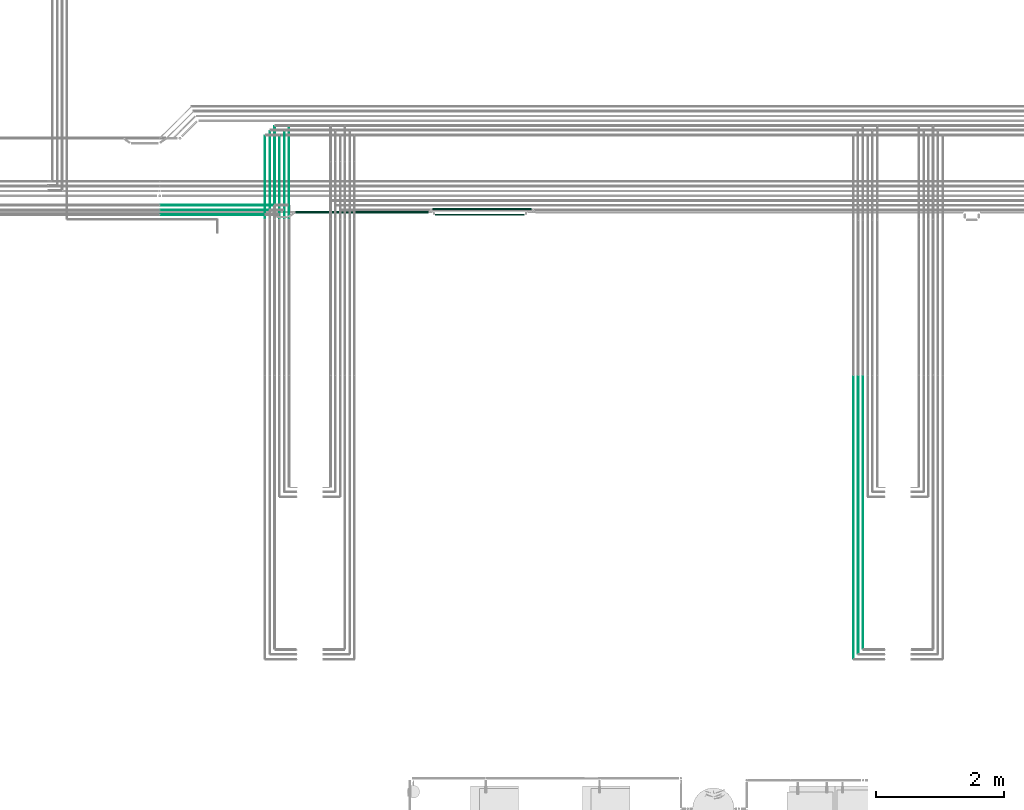
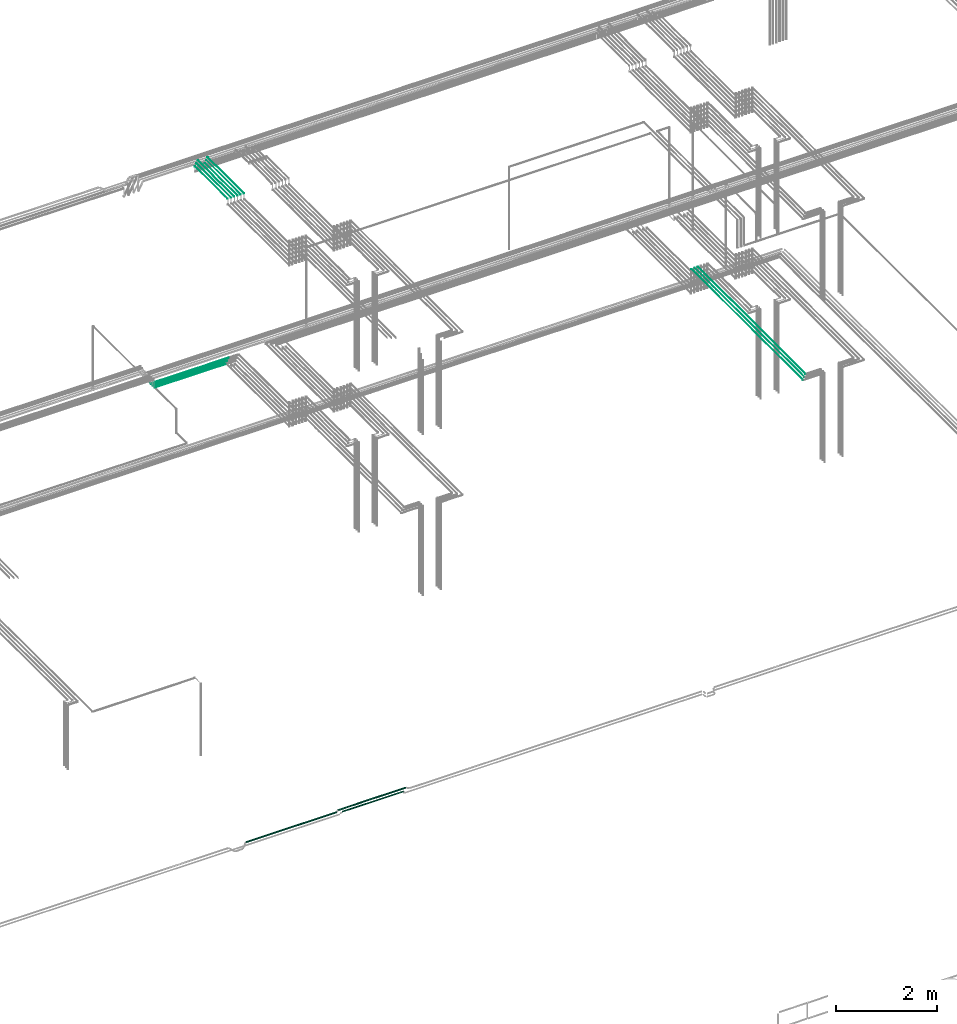
# One storey, part 55 of 331: 15 flow segments.
"""IFC2X3 building model written with IfcOpenShell, lengths in millimetres."""

from ifc_helpers import new_model, entity, si_unit, converted_unit, derived_unit, direction, frame, frame_2d, origin, origin_2d_with_axis, place, context, subcontext, project, spatial, circle, extrude, type_object, element, save


model = new_model("IFC2X3")

# Units and contexts
model_context = context("Model", 3, precision=0.01, world=origin(), true_north=direction((6.12303176911189e-17, 1.0)))
body_context = subcontext(model_context, "Body", "Model", "MODEL_VIEW")
ifc_project = project(units=[si_unit("LENGTHUNIT", "METRE", prefix="MILLI"), si_unit("AREAUNIT", "SQUARE_METRE"), si_unit("VOLUMEUNIT", "CUBIC_METRE"), converted_unit("PLANEANGLEUNIT", "DEGREE", entity("IfcRatioMeasure", 0.0174532925199433), si_unit("PLANEANGLEUNIT", "RADIAN"), dimensions=[0, 0, 0, 0, 0, 0, 0]), si_unit("MASSUNIT", "GRAM", prefix="KILO"), derived_unit("MASSDENSITYUNIT", [(si_unit("MASSUNIT", "GRAM", prefix="KILO"), 1), (si_unit("LENGTHUNIT", "METRE"), -3)]), derived_unit("MOMENTOFINERTIAUNIT", [(si_unit("LENGTHUNIT", "METRE"), 4)]), si_unit("TIMEUNIT", "SECOND"), si_unit("FREQUENCYUNIT", "HERTZ"), si_unit("THERMODYNAMICTEMPERATUREUNIT", "DEGREE_CELSIUS"), derived_unit("THERMALTRANSMITTANCEUNIT", [(si_unit("MASSUNIT", "GRAM", prefix="KILO"), 1), (si_unit("THERMODYNAMICTEMPERATUREUNIT", "KELVIN"), -1), (si_unit("TIMEUNIT", "SECOND"), -3)]), derived_unit("VOLUMETRICFLOWRATEUNIT", [(si_unit("LENGTHUNIT", "METRE"), 3), (si_unit("TIMEUNIT", "SECOND"), -1)]), derived_unit("MASSFLOWRATEUNIT", [(si_unit("MASSUNIT", "GRAM", prefix="KILO"), 1), (si_unit("TIMEUNIT", "SECOND"), -1)]), derived_unit("ROTATIONALFREQUENCYUNIT", [(si_unit("TIMEUNIT", "SECOND"), -1)]), si_unit("ELECTRICCURRENTUNIT", "AMPERE"), si_unit("ELECTRICVOLTAGEUNIT", "VOLT"), si_unit("POWERUNIT", "WATT"), si_unit("FORCEUNIT", "NEWTON", prefix="KILO"), si_unit("ILLUMINANCEUNIT", "LUX"), si_unit("LUMINOUSFLUXUNIT", "LUMEN"), si_unit("LUMINOUSINTENSITYUNIT", "CANDELA"), derived_unit("USERDEFINED", [(si_unit("MASSUNIT", "GRAM", prefix="KILO"), -1), (si_unit("LENGTHUNIT", "METRE"), -2), (si_unit("TIMEUNIT", "SECOND"), 3), (si_unit("LUMINOUSFLUXUNIT", "LUMEN"), 1)]), derived_unit("LINEARVELOCITYUNIT", [(si_unit("LENGTHUNIT", "METRE"), 1), (si_unit("TIMEUNIT", "SECOND"), -1)]), si_unit("PRESSUREUNIT", "PASCAL"), derived_unit("USERDEFINED", [(si_unit("LENGTHUNIT", "METRE"), -2), (si_unit("MASSUNIT", "GRAM", prefix="KILO"), 1), (si_unit("TIMEUNIT", "SECOND"), -2)]), derived_unit("LINEARFORCEUNIT", [(si_unit("MASSUNIT", "GRAM", prefix="KILO"), 1), (si_unit("LENGTHUNIT", "METRE"), 1), (si_unit("TIMEUNIT", "SECOND"), -2), (si_unit("LENGTHUNIT", "METRE"), -1)]), derived_unit("PLANARFORCEUNIT", [(si_unit("MASSUNIT", "GRAM", prefix="KILO"), 1), (si_unit("LENGTHUNIT", "METRE"), 1), (si_unit("TIMEUNIT", "SECOND"), -2), (si_unit("LENGTHUNIT", "METRE"), -2)])], contexts=[model_context])

# Site, building, storey
site_placement = place(None, frame((0.0, -0.00077364408347762, 0.0)))
site = spatial("IfcSite", under=ifc_project, at=site_placement, CompositionType="ELEMENT")
building_placement = place(site_placement, origin())
building = spatial("IfcBuilding", under=site, at=building_placement, CompositionType="ELEMENT")
storey_placement = place(building_placement, origin())
storey = spatial("IfcBuildingStorey", under=building, at=storey_placement, CompositionType="ELEMENT", Elevation=0.0)

# Flow segments
pipe_segment_type = type_object("IfcPipeSegmentType", PredefinedType="NOTDEFINED")
flow_segment_1_placement = place(storey_placement, frame((52813.0441030245, 1365.48876707953, 15142.4047277641)))
element("IfcFlowSegment", 1, at=flow_segment_1_placement, inside=storey, type_object=pipe_segment_type, context=body_context, shape_type="SweptSolid", body=[
    extrude(circle(Radius=6.0, at=frame_2d((0.0, 2.16573425859679e-12), x_axis=(1.0, 0.0))), frame((7.59527223591454, 0.0, 7.59527223591887), z_axis=(0.0, 1.0, 0.0), x_axis=(1.0, 0.0, 0.0)), (0.0, 0.0, 1.0), 4264.13179674781),
])
flow_segment_2_placement = place(storey_placement, frame((52740.0441030245, 1286.48876707969, 15144.4047277641)))
element("IfcFlowSegment", 2, at=flow_segment_2_placement, inside=storey, type_object=pipe_segment_type, context=body_context, shape_type="SweptSolid", body=[
    extrude(circle(Radius=4.0, at=origin_2d_with_axis()), frame((5.59527223591499, 0.0, 5.59527223591499), z_axis=(0.0, 1.0, 0.0), x_axis=(1.0, 0.0, 0.0)), (0.0, 0.0, 1.0), 4347.13179674766),
])
flow_segment_3_placement = place(storey_placement, frame((52665.0441030245, 1211.48876707959, 15144.4047277641)))
element("IfcFlowSegment", 3, at=flow_segment_3_placement, inside=storey, type_object=pipe_segment_type, context=body_context, shape_type="SweptSolid", body=[
    extrude(circle(Radius=4.0, at=origin_2d_with_axis()), frame((5.59527223591499, 0.0, 5.59527223591499), z_axis=(0.0, 1.0, 0.0), x_axis=(1.0, 0.0, 0.0)), (0.0, 0.0, 1.0), 4422.13179674775),
])
flow_segment_4_placement = place(storey_placement, frame((41839.1806008089, 8296.91467161339, 14540.9042780896)))
element("IfcFlowSegment", 4, at=flow_segment_4_placement, inside=storey, type_object=pipe_segment_type, context=body_context, shape_type="SweptSolid", body=[
    extrude(circle(Radius=7.5, at=frame_2d((9.74580416368554e-12, -7.00319197907049e-30), x_axis=(1.0, 0.0))), frame((0.0, 9.09527223592611, 9.09527223591636), z_axis=(1.0, 0.0, 0.0), x_axis=(0.0, 1.0, 0.0)), (0.0, 0.0, 1.0), 1773.92792606957),
])
flow_segment_5_placement = place(storey_placement, frame((41835.1806026719, 8223.41467161339, 14542.4036519153)))
element("IfcFlowSegment", 5, at=flow_segment_5_placement, inside=storey, type_object=pipe_segment_type, context=body_context, shape_type="SweptSolid", body=[
    extrude(circle(Radius=6.0, at=frame_2d((9.74580416368554e-12, 0.0), x_axis=(1.0, 0.0))), frame((0.0, 7.59527223592536, 7.5952722359167), z_axis=(1.0, 0.0, 0.0), x_axis=(0.0, 1.0, 0.0)), (0.0, 0.0, 1.0), 1703.92793254129),
])
flow_segment_6_placement = place(storey_placement, frame((41835.1806039076, 8148.41467161336, 14542.4047277641)))
element("IfcFlowSegment", 6, at=flow_segment_6_placement, inside=storey, type_object=pipe_segment_type, context=body_context, shape_type="SweptSolid", body=[
    extrude(circle(Radius=6.0, at=frame_2d((1.73258740687743e-11, 0.0), x_axis=(1.0, 0.0))), frame((0.0, 7.59527223593186, 7.5952722359167), z_axis=(1.0, 0.0, 0.0), x_axis=(0.0, 1.0, 0.0)), (0.0, 0.0, 1.0), 1628.92792738445),
])
flow_segment_7_placement = place(storey_placement, frame((43464.4468045266, 8100.14880665486, 18574.4047277641)))
element("IfcFlowSegment", 7, at=flow_segment_7_placement, inside=storey, type_object=pipe_segment_type, context=body_context, shape_type="SweptSolid", body=[
    extrude(circle(Radius=4.0, at=origin_2d_with_axis()), frame((5.59527223591499, 0.0, 5.59527223591499), z_axis=(0.0, 1.0, 0.0), x_axis=(-1.0, 0.0, 0.0)), (0.0, 0.0, 1.0), 1289.85119334508),
])
flow_segment_8_placement = place(storey_placement, frame((43539.4468045266, 8100.14880665486, 18574.4047277641)))
element("IfcFlowSegment", 8, at=flow_segment_8_placement, inside=storey, type_object=pipe_segment_type, context=body_context, shape_type="SweptSolid", body=[
    extrude(circle(Radius=4.0, at=origin_2d_with_axis()), frame((5.59527223591499, 0.0, 5.59527223591499), z_axis=(0.0, 1.0, 0.0), x_axis=(-1.0, 0.0, 0.0)), (0.0, 0.0, 1.0), 1364.85119334511),
])
flow_segment_9_placement = place(building_placement, frame((43612.4468045266, 8104.14880665494, 18572.4047277641)))
element("IfcFlowSegment", 9, at=flow_segment_9_placement, inside=storey, type_object=pipe_segment_type, context=body_context, shape_type="SweptSolid", body=[
    extrude(circle(Radius=6.0, at=origin_2d_with_axis()), frame((7.59527223591454, 0.0, 7.5952722359167), z_axis=(0.0, 1.0, 0.0), x_axis=(1.0, 0.0, 0.0)), (0.0, 0.0, 1.0), 1431.85119334503),
])
flow_segment_10_placement = place(building_placement, frame((43689.4468045266, 8100.14880665493, 18574.4047277641)))
element("IfcFlowSegment", 10, at=flow_segment_10_placement, inside=storey, type_object=pipe_segment_type, context=body_context, shape_type="SweptSolid", body=[
    extrude(circle(Radius=4.0, at=origin_2d_with_axis()), frame((5.59527223593232, 0.0, 5.59527223591499), z_axis=(0.0, 1.0, 0.0), x_axis=(1.0, 0.0, 0.0)), (0.0, 0.0, 1.0), 1289.85119334501),
])
flow_segment_11_placement = place(building_placement, frame((43764.4468045266, 8100.14880665494, 18574.4047277641)))
element("IfcFlowSegment", 11, at=flow_segment_11_placement, inside=storey, type_object=pipe_segment_type, context=body_context, shape_type="SweptSolid", body=[
    extrude(circle(Radius=4.0, at=origin_2d_with_axis()), frame((5.59527223591499, 0.0, 5.59527223591499), z_axis=(0.0, 1.0, 0.0), x_axis=(1.0, 0.0, 0.0)), (0.0, 0.0, 1.0), 1364.85119334503),
])
flow_segment_12_placement = place(building_placement, frame((43837.4468045266, 8104.14880665494, 18572.4047277641)))
element("IfcFlowSegment", 12, at=flow_segment_12_placement, inside=storey, type_object=pipe_segment_type, context=body_context, shape_type="SweptSolid", body=[
    extrude(circle(Radius=6.0, at=frame_2d((-8.66293703438714e-12, 0.0), x_axis=(1.0, 0.0))), frame((7.59527223591454, 0.0, 7.5952722359167), z_axis=(0.0, 1.0, 0.0), x_axis=(-1.0, 0.0, 0.0)), (0.0, 0.0, 1.0), 1431.85119334503),
])
flow_segment_13_placement = place(building_placement, frame((43950.4720063486, 8179.92098945661, 2759.40472776402)))
element("IfcFlowSegment", 13, at=flow_segment_13_placement, inside=storey, type_object=pipe_segment_type, context=body_context, shape_type="SweptSolid", body=[
    extrude(circle(Radius=14.0, at=frame_2d((5.41433564649196e-12, 0.0), x_axis=(1.0, 0.0))), frame((0.0, 15.5952722359203, 15.595272235916), z_axis=(1.0, 0.0, 0.0), x_axis=(0.0, 1.0, 0.0)), (0.0, 0.0, 1.0), 2069.01189168578),
])
flow_segment_14_placement = place(building_placement, frame((46088.4838980344, 8228.92098945662, 2759.40472776402)))
element("IfcFlowSegment", 14, at=flow_segment_14_placement, inside=storey, type_object=pipe_segment_type, context=body_context, shape_type="SweptSolid", body=[
    extrude(circle(Radius=14.0, at=frame_2d((2.16573425859679e-12, 0.0), x_axis=(1.0, 0.0))), frame((0.0, 15.595272235916, 15.595272235916), z_axis=(1.0, 0.0, 0.0), x_axis=(0.0, 1.0, 0.0)), (0.0, 0.0, 1.0), 1541.88047541324),
])
flow_segment_15_placement = place(building_placement, frame((46133.7983299503, 8142.92098945674, 2762.40472776403)))
element("IfcFlowSegment", 15, at=flow_segment_15_placement, inside=storey, type_object=pipe_segment_type, context=body_context, shape_type="SweptSolid", body=[
    extrude(circle(Radius=11.0, at=frame_2d((0.0, -5.41433564649196e-13), x_axis=(1.0, 0.0))), frame((0.0, 12.5952722359166, 12.5952722359156), z_axis=(1.0, 0.0, 0.0), x_axis=(0.0, -1.0, 0.0)), (0.0, 0.0, 1.0), 1392.0),
])

save(model, "model.ifc")
